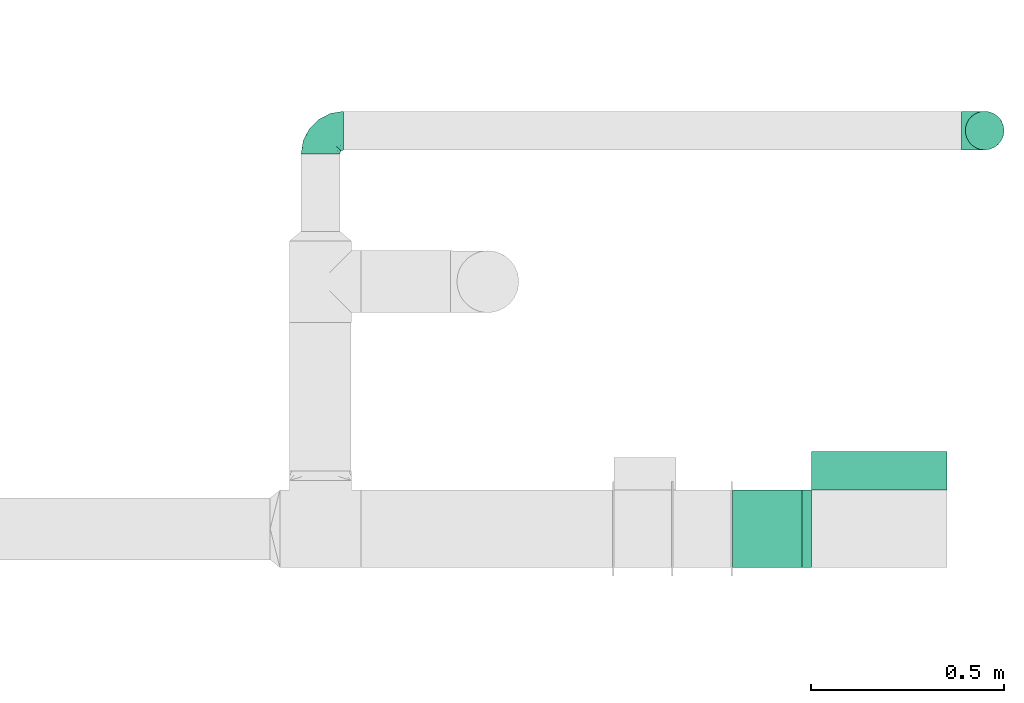
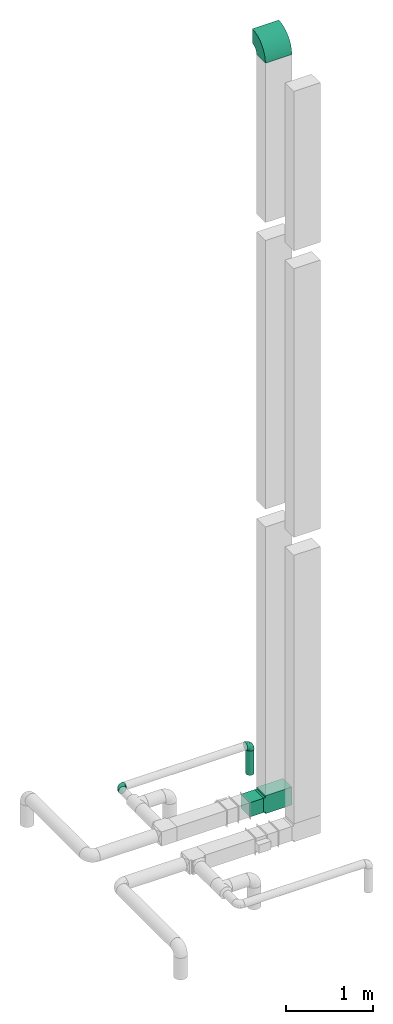
# One storey, part 11 of 12: 4 flow fittings, 2 flow segments.
"""IFC2X3 building model written with IfcOpenShell, lengths in millimetres."""

from ifc_helpers import new_model, entity, si_unit, converted_unit, derived_unit, direction, frame, frame_2d, origin, origin_2d_with_axis, place, context, subcontext, project, spatial, polyline, circle_curve, parameter, trimmed, segment, composite_curve, rectangle, circle, outline, extrude, faceted_brep, source, transform, mapped, type_object, type_shapes, element, save


model = new_model("IFC2X3")

# Units and contexts
model_context = context("Model", 3, precision=0.01, world=origin(), true_north=direction((6.12303176911189e-17, 1.0)))
body_context = subcontext(model_context, "Body", "Model", "MODEL_VIEW")
ifc_project = project(units=[si_unit("LENGTHUNIT", "METRE", prefix="MILLI"), si_unit("AREAUNIT", "SQUARE_METRE"), si_unit("VOLUMEUNIT", "CUBIC_METRE"), converted_unit("PLANEANGLEUNIT", "DEGREE", entity("IfcRatioMeasure", 0.0174532925199433), si_unit("PLANEANGLEUNIT", "RADIAN"), dimensions=[0, 0, 0, 0, 0, 0, 0]), si_unit("MASSUNIT", "GRAM", prefix="KILO"), derived_unit("MASSDENSITYUNIT", [(si_unit("MASSUNIT", "GRAM", prefix="KILO"), 1), (si_unit("LENGTHUNIT", "METRE"), -3)]), si_unit("TIMEUNIT", "SECOND"), si_unit("FREQUENCYUNIT", "HERTZ"), si_unit("THERMODYNAMICTEMPERATUREUNIT", "DEGREE_CELSIUS"), derived_unit("THERMALTRANSMITTANCEUNIT", [(si_unit("MASSUNIT", "GRAM", prefix="KILO"), 1), (si_unit("THERMODYNAMICTEMPERATUREUNIT", "KELVIN"), -1), (si_unit("TIMEUNIT", "SECOND"), -3)]), derived_unit("VOLUMETRICFLOWRATEUNIT", [(si_unit("LENGTHUNIT", "METRE"), 3), (si_unit("TIMEUNIT", "SECOND"), -1)]), si_unit("ELECTRICCURRENTUNIT", "AMPERE"), si_unit("ELECTRICVOLTAGEUNIT", "VOLT"), si_unit("POWERUNIT", "WATT"), si_unit("FORCEUNIT", "NEWTON", prefix="KILO"), si_unit("ILLUMINANCEUNIT", "LUX"), si_unit("LUMINOUSFLUXUNIT", "LUMEN"), si_unit("LUMINOUSINTENSITYUNIT", "CANDELA"), derived_unit("USERDEFINED", [(si_unit("MASSUNIT", "GRAM", prefix="KILO"), -1), (si_unit("LENGTHUNIT", "METRE"), -2), (si_unit("TIMEUNIT", "SECOND"), 3), (si_unit("LUMINOUSFLUXUNIT", "LUMEN"), 1)]), derived_unit("LINEARVELOCITYUNIT", [(si_unit("LENGTHUNIT", "METRE"), 1), (si_unit("TIMEUNIT", "SECOND"), -1)]), si_unit("PRESSUREUNIT", "PASCAL"), derived_unit("USERDEFINED", [(si_unit("LENGTHUNIT", "METRE"), -2), (si_unit("MASSUNIT", "GRAM", prefix="KILO"), 1), (si_unit("TIMEUNIT", "SECOND"), -2)])], contexts=[model_context])

# Site, building, storey
site_placement = place(None, origin())
site = spatial("IfcSite", under=ifc_project, at=site_placement, CompositionType="ELEMENT")
building_placement = place(site_placement, origin())
building = spatial("IfcBuilding", under=site, at=building_placement, CompositionType="ELEMENT")
storey_placement = place(building_placement, frame((0.0, 0.0, 4000.0)))
storey = spatial("IfcBuildingStorey", under=building, at=storey_placement, Name="01 Level", CompositionType="ELEMENT", Elevation=4000.0)

# Flow segments
duct_segment_type_1 = type_object("IfcDuctSegmentType", Name="Round Duct:Air", PredefinedType="NOTDEFINED")
flow_segment_1_placement = place(storey_placement, frame((24851.8947986159, -67528.1388300248, 2603.07847999992)))
element("IfcFlowSegment", 1, at=flow_segment_1_placement, inside=storey, type_object=duct_segment_type_1, Name="Round Duct:Air", ObjectType="Round Duct:Air", context=body_context, shape_type="SweptSolid", body=[
    extrude(circle(Radius=50.0, at=origin_2d_with_axis()), frame((51.5952722359175, 51.5952722359132, 0.0), z_axis=(0.0, 0.0, 1.0), x_axis=(0.0, 1.0, 0.0)), (0.0, 0.0, 1.0), 336.921519999948),
])
duct_segment_type_2 = type_object("IfcDuctSegmentType", Name="Rectangular Duct:Air", PredefinedType="NOTDEFINED")
flow_segment_2_placement = place(storey_placement, frame((24250.9900708518, -68606.4439409626, 2900.0)))
element("IfcFlowSegment", 2, at=flow_segment_2_placement, inside=storey, type_object=duct_segment_type_2, Name="Rectangular Duct:Air", ObjectType="Rectangular Duct:Air", context=body_context, shape_type="SweptSolid", body=[
    extrude(rectangle(XDim=179.671447124557, YDim=199.999999999998, at=frame_2d((0.0, -4.33431068813661e-12), x_axis=(1.0, 0.0))), frame((89.8357235622787, 100.0, 0.0)), (0.0, 0.0, 1.0), 200.0),
])

# Flow fittings
duct_fitting_type_1 = type_object("IfcDuctFittingType", Name="Air_Elbow short_Circ", PredefinedType="NOTDEFINED")
shared_shape_1 = source(origin(), body_context, "Body", "Brep", [
    faceted_brep([(-60.0, -12.9409522551261, -48.2962913144533), (-60.0, -25.0, -43.3012701892219), (-60.0, -35.3553390593274, -35.3553390593273), (-60.0, -43.3012701892219, -25.0), (-60.0, -48.2962913144534, -12.940952255126), (-60.0, -50.0, 0.0), (-60.0, -48.2962913144533, 12.9409522551263), (-60.0, -43.3012701892217, 25.0), (-60.0, -35.3553390593271, 35.3553390593275), (-60.0, -25.0, 43.301270189222), (-60.0, -18.9704761275628, 45.7987807518377), (-60.0, -12.9409522551258, 48.2962913144534), (-60.0, 0.0, 50.0), (-60.0, 12.9409522551262, 48.2962913144533), (-60.0, 25.0, 43.3012701892218), (-60.0, 35.3553390593275, 35.3553390593272), (-60.0, 43.301270189222, 25.0), (-60.0, 48.2962913144534, 12.9409522551259), (-60.0, 50.0, 0.0), (-60.0, 48.2962913144533, -12.9409522551262), (-60.0, 43.3012701892218, -25.0), (-60.0, 35.3553390593273, -35.3553390593274), (-60.0, 25.0, -43.3012701892219), (-60.0, 12.9409522551259, -48.2962913144534), (-60.0, 0.0, -50.0), (0.0, -60.0, -50.0), (12.9409522551268, -60.0, -48.2962913144534), (25.0, -60.0, -43.3012701892219), (35.3553390593281, -60.0, -35.3553390593274), (43.3012701892227, -60.0, -25.0), (48.2962913144542, -60.0, -12.9409522551262), (50.0, -60.0, 0.0), (48.2962913144543, -60.0, 12.9409522551259), (43.3012701892229, -60.0, 25.0), (35.3553390593284, -60.0, 35.3553390593272), (25.0, -60.0, 43.3012701892218), (12.9409522551271, -60.0, 48.2962913144533), (0.0, -60.0, 50.0), (-12.9409522551249, -60.0, 48.2962913144534), (-25.0, -60.0, 43.301270189222), (-35.3553390593263, -60.0, 35.3553390593275), (-43.3012701892209, -60.0, 25.0), (-48.2962913144524, -60.0, 12.9409522551263), (-50.0, -60.0, 0.0), (-48.2962913144525, -60.0, -12.940952255126), (-43.301270189221, -60.0, -25.0), (-35.3553390593265, -60.0, -35.3553390593273), (-25.0, -60.0, -43.3012701892219), (-18.9704761275622, -60.0, -45.7987807518376), (-12.9409522551252, -60.0, -48.2962913144533), (-34.4613055182162, 40.2781615499549, 24.6893391361235), (-41.7413930879589, 46.3367006663211, 14.3622192349088), (-49.0564079906538, 40.7801415025898, 28.076858272246), (-43.0040653093767, 47.3081083962334, 0.0), (-46.9531334224505, -28.9691372331723, 42.5007483631415), (-49.945230570524, -14.009456366224, 48.3010541644054), (46.3367008388525, -41.7413924405609, 14.3622183025403), (-28.9195822317624, 34.3595042325614, 30.8522337271345), (-16.4026032888538, 28.8335615486346, 31.3447155376829), (-20.8886043148544, 37.032907476011, 22.5646988156665), (8.51327307359233, -29.8490270681828, 47.7425705251578), (21.5851347328685, -39.3600400603544, 43.7780030266717), (18.1051423029501, -18.6630708487668, 41.1725129713058), (-3.94145017646366, -44.1513377558611, 49.9695692624666), (-16.993357552601, -43.112835299455, 48.0588376259554), (-29.8490305613342, 8.51327565171467, 47.7425702287428), (-18.6630773197735, 18.1051465687322, 41.1725124591201), (-39.360041631582, 21.585137213725, 43.7780019122438), (-41.9572959526986, 32.3456520264411, 36.575294220854), (-28.3738768436699, 26.9110252548877, 38.0083212356069), (-47.8035915916317, -49.3365848090307, 24.1167211667097), (-51.9080682539527, -51.9080682564403, 11.9284381035673), (-28.9388870718402, -47.4392187660381, 42.4028289139121), (-46.4119732313288, 8.97786791845547, 48.9268647037242), (15.3655862372502, 1.44443599762982, 33.3656926605527), (12.7026747916207, 16.0653579926251, 21.330563165355), (-0.0901680697707372, 16.249793899354, 33.6631038709893), (-26.0984306641832, -9.4519602521943, 49.9925353018775), (-43.5357165770215, -3.92607608695299, 49.9756911723036), (-40.3512409746586, -17.2001159603688, 48.3058104561749), (-51.5116032222349, -38.9116886125261, 33.3337470302399), (40.2781623134548, -34.4613024546835, 24.689336501659), (34.3595052098631, -28.9195768148052, 30.852230382061), (32.3456522233896, -41.9572963751397, 36.5752941161915), (-52.6192947824697, -44.3162483434043, 26.0687788699409), (8.97786691245749, -46.4119718726044, 48.9268648562795), (35.0507691245895, -17.8379542600364, 23.7817320689175), (-0.154113830211583, 27.0441585303382, 20.4371969134619), (0.164802122834046, 30.9507973718637, 9.70158150296541), (-10.9191638901366, 35.9593562872322, 14.7243484546897), (40.7801421145919, -49.0564069362065, 28.0768572079665), (42.5446020921407, -25.3772134428819, 13.1791087429088), (23.1044280783399, 10.2139010010231, 10.911201952746), (10.303795037543, 23.1674391280597, 10.425151792526), (47.3081083962343, -43.0040653093781, 0.0), (44.6162167924678, -26.008130618756, 0.0), (-32.7984308187714, -33.1644722725009, 45.0025999357929), (-41.6246972537655, -41.624696659769, 36.6481760707585), (-16.0198594588589, -0.790040969679908, 48.0702532559686), (-7.74597844975689, -15.8760781607658, 49.2907901610601), (-10.2505184648613, -32.0701285913551, 49.9130990257927), (-52.9289321881336, -52.9289321881345, 0.0), (-38.9116885130941, -51.5116028691678, 33.3337472807585), (27.3373523634918, -28.9262874076833, 37.8242669720924), (28.8335585354312, -16.4025932897411, 31.3447134244473), (-10.6758764332908, 36.8040430868554, 0.0), (-21.0820556464647, -25.013405385062, 49.4085637061446), (-25.3772163464242, 42.5446022063287, 13.179111746218), (-29.4708300504911, -18.1716321771538, 49.3204506255928), (-0.613576836584022, -32.0726800049485, 49.6825501479137), (-26.0081306187546, 44.6162167924668, 0.0), (-1.21981718883359, -1.21981162112378, 44.3295369128094), (7.809323786389, -12.5506490133832, 44.518448707346), (4.65637775217312, 28.991869381244, 0.0), (30.9271083665945, 0.192011278925337, 9.72551394481069), (25.4694098156993, 0.899564345657441, 21.9045256717261), (36.8040430868565, -10.6758764332921, 0.0), (8.17237141004653, -0.709602060124845, 39.7363553078916), (-1.20691178924098, 8.42774890414073, 39.8368437988478), (-11.8311378719951, 8.12805454147699, 44.1670059112514), (16.8241235667092, 16.8241235667079, 0.0), (35.9593546638031, -10.9191599029529, 14.7243472530362), (28.9918693812452, 4.65637775217184, 0.0), (-14.0094588862512, -49.9452236085703, -48.3010539035587), (-25.3772156484835, 42.5446019119684, -13.1791119497906), (-34.4613048910139, 40.2781614393135, -24.6893390523416), (-41.7413926252934, 46.3367005832334, -14.3622192468898), (-43.1128355702084, -16.9933564311214, -48.0588378972243), (-44.1513388294639, -3.94144876101963, -49.969569299814), (-51.5116035577561, -38.9116884747343, -33.3337470330805), (-41.62469790636, -41.6246960630329, -36.6481760341003), (-49.3365851024771, -47.8035917204495, -24.1167206397972), (16.0653446591387, 12.7026862735946, -21.330566780897), (10.2138986720569, 23.1044286164337, -10.9112068363266), (23.1674375203698, 10.3037953844737, -10.4251565011195), (27.0441512446144, -0.154114142874967, -20.4372107139949), (30.9507965291521, 0.164803474452689, -9.70158128624016), (35.9593546209329, -10.9191616413996, -14.7243499458666), (-28.9262923378956, 27.3373567288812, -37.8242648451571), (-16.4026019873643, 28.8335613017021, -31.344715100551), (-18.6630757642047, 18.1051470727615, -41.1725116507822), (-0.79004904716724, -16.0198534732482, -48.0702540902608), (-9.45196719952168, -26.0984311316614, -49.9925354060889), (-15.8760743141415, -7.74597807562093, -49.2907896898935), (-25.0134056140136, -21.0820528609103, -49.4085640038716), (-49.0564077792961, 40.7801415002595, -28.0768582420378), (-33.1644687800828, -32.7984277324913, -45.0026021871039), (-47.4392196421628, -28.9388866268174, -42.4028289664685), (-51.9080682748156, -51.9080682458111, -11.9284380741106), (-39.3600407942016, 21.5851376014369, -43.7780015915287), (-41.9572952892088, 32.3456521258773, -36.5752940113004), (-29.8490289400598, 8.5132766456386, -47.7425697425162), (-46.411972568153, 8.97786849540185, -48.9268645575236), (-17.8379596675892, 35.0507702162708, -23.7817342784206), (-28.9195813138317, 34.3595041939927, -30.8522334076151), (18.1051443153088, -18.6630730295509, -41.1725124486671), (26.9110256448416, -28.3738769796432, -38.0083209621406), (21.5851368100191, -39.3600388626355, -43.7780017534797), (-44.316248159738, -52.6192941440622, -26.0687795868405), (-38.911688364674, -51.5116023985273, -33.3337476311683), (-3.92607321834031, -43.5357049838062, -49.9756913600445), (-17.2001201011705, -40.3512365316697, -48.3058099460363), (8.97786798225732, -46.4119703958823, -48.9268645751331), (8.51327412363391, -29.8490256018375, -47.7425700423665), (40.7801413413476, -49.0564079294803, -28.0768584987253), (-28.969136268001, -46.9531365639949, -42.5007481599507), (1.44442453081588, 15.3655954628303, -33.3656927670723), (16.2497893015437, -0.0901603719773552, -33.6631026184802), (32.3456517066656, -41.9572939682546, -36.5752941586943), (46.3367004266908, -41.7413922128929, -14.3622195286513), (28.8335602968518, -16.402602640196, -31.3447165791004), (37.0329066484517, -20.888602858321, -22.564699256686), (34.3595039081184, -28.9195810717321, -30.8522336573022), (40.2781610753798, -34.461304879185, -24.6893396682814), (-32.0701289123428, -10.2505155181949, -49.9130991682027), (42.5446013435109, -25.3772148558883, -13.1791129929581), (-18.17163862849, -29.4708285244359, -49.3204499074468), (-32.0726819537407, -0.61357350659226, -49.6825499006192), (-1.21981337419447, -1.21981084831843, -44.3295352204376), (-12.5506417422758, 7.80933382246174, -44.5184423716321), (0.192009591001318, 30.9271092740971, -9.72551482732434), (0.899550937376629, 25.4694163362272, -21.9045307406697), (-0.709596078235449, 8.17237239935393, -39.7363517396473), (8.42775025848031, -1.2069144200305, -39.8368443201002), (8.12805004108825, -11.8311369938791, -44.1670075921659), (-10.9191629014402, 35.9593557213529, -14.724348628576)], [[[0, 1, 2, 3, 4, 5, 6, 7, 8, 9, 10, 11, 12, 13, 14, 15, 16, 17, 18, 19, 20, 21, 22, 23, 24]], [[25, 26, 27, 28, 29, 30, 31, 32, 33, 34, 35, 36, 37, 38, 39, 40, 41, 42, 43, 44, 45, 46, 47, 48, 49]], [[50, 51, 52]], [[18, 17, 53]], [[9, 54, 55]], [[32, 56, 33]], [[57, 58, 59]], [[60, 61, 62]], [[63, 64, 38]], [[65, 66, 67]], [[67, 68, 14]], [[68, 69, 57]], [[42, 70, 71]], [[52, 16, 15]], [[64, 72, 39]], [[73, 13, 12]], [[74, 75, 76]], [[55, 11, 10, 9]], [[77, 78, 79]], [[67, 14, 13]], [[17, 16, 51]], [[7, 80, 8]], [[81, 82, 83]], [[7, 84, 80]], [[8, 54, 9]], [[72, 40, 39]], [[5, 71, 6]], [[73, 65, 67]], [[85, 37, 36]], [[7, 6, 84]], [[85, 36, 61]], [[81, 86, 82]], [[87, 88, 89]], [[35, 61, 36]], [[33, 90, 34]], [[38, 37, 63]], [[91, 81, 56]], [[90, 33, 56]], [[35, 83, 61]], [[75, 92, 93]], [[94, 95, 56]], [[96, 97, 72]], [[98, 77, 99]], [[64, 63, 100]], [[71, 5, 101]], [[68, 15, 14]], [[43, 71, 101]], [[66, 69, 67]], [[70, 102, 97]], [[103, 104, 62]], [[40, 102, 41]], [[105, 89, 88]], [[70, 42, 41]], [[96, 72, 64]], [[77, 106, 99]], [[64, 39, 38]], [[78, 12, 11]], [[59, 89, 107]], [[35, 34, 83]], [[91, 86, 81]], [[51, 53, 17]], [[56, 32, 94]], [[12, 78, 73]], [[106, 77, 108]], [[96, 108, 79]], [[97, 54, 80]], [[40, 72, 102]], [[96, 54, 97]], [[106, 64, 100]], [[85, 109, 63]], [[61, 83, 103]], [[81, 83, 90]], [[15, 68, 52]], [[50, 68, 57]], [[77, 65, 78]], [[53, 51, 110]], [[94, 32, 31]], [[65, 77, 98]], [[111, 99, 112]], [[63, 109, 100]], [[107, 51, 50]], [[93, 113, 88]], [[114, 92, 115]], [[74, 62, 104]], [[115, 74, 104]], [[91, 95, 116]], [[112, 117, 111]], [[115, 75, 74]], [[117, 118, 111]], [[111, 118, 119]], [[58, 66, 76]], [[111, 119, 98]], [[87, 58, 76]], [[118, 117, 74]], [[54, 96, 79]], [[106, 96, 64]], [[120, 113, 93]], [[86, 121, 115]], [[122, 92, 114]], [[120, 92, 122]], [[115, 92, 75]], [[120, 93, 92]], [[87, 75, 93]], [[75, 87, 76]], [[58, 87, 59]], [[37, 85, 63]], [[60, 85, 61]], [[13, 73, 67]], [[65, 73, 78]], [[107, 110, 51]], [[121, 116, 114]], [[116, 121, 91]], [[91, 56, 95]], [[41, 102, 70]], [[97, 102, 72]], [[8, 80, 54]], [[70, 97, 84]], [[100, 99, 106]], [[60, 99, 109]], [[100, 109, 99]], [[60, 109, 85]], [[93, 88, 87]], [[89, 105, 107]], [[80, 84, 97]], [[71, 70, 84]], [[84, 6, 71]], [[42, 71, 43]], [[16, 52, 51]], [[50, 52, 68]], [[34, 90, 83]], [[81, 90, 56]], [[79, 78, 55]], [[11, 55, 78]], [[54, 79, 55]], [[61, 103, 62]], [[104, 103, 82]], [[83, 82, 103]], [[104, 82, 86]], [[104, 86, 115]], [[91, 121, 86]], [[50, 57, 59]], [[58, 57, 69]], [[58, 69, 66]], [[67, 69, 68]], [[50, 59, 107]], [[87, 89, 59]], [[106, 108, 96]], [[108, 77, 79]], [[66, 65, 119]], [[111, 98, 99]], [[98, 119, 65]], [[76, 66, 118]], [[119, 118, 66]], [[76, 118, 74]], [[117, 62, 74]], [[62, 117, 112]], [[112, 60, 62]], [[60, 112, 99]], [[110, 107, 105]], [[105, 88, 113]], [[122, 114, 116]], [[121, 114, 115]], [[49, 48, 47, 123]], [[124, 125, 126]], [[0, 127, 1]], [[128, 0, 24]], [[129, 130, 131]], [[132, 133, 134]], [[2, 129, 3]], [[135, 136, 137]], [[131, 4, 3]], [[138, 139, 140]], [[141, 142, 143]], [[143, 142, 144]], [[145, 20, 126]], [[146, 130, 147]], [[53, 110, 126]], [[4, 131, 148]], [[149, 22, 150]], [[151, 149, 140]], [[22, 149, 23]], [[146, 147, 127]], [[147, 2, 1]], [[21, 20, 145]], [[150, 22, 21]], [[149, 152, 23]], [[125, 153, 154]], [[125, 154, 150]], [[148, 101, 5]], [[124, 153, 125]], [[148, 44, 43]], [[155, 156, 157]], [[158, 159, 45]], [[157, 27, 26]], [[116, 137, 136]], [[45, 159, 46]], [[1, 127, 147]], [[142, 160, 161]], [[162, 163, 157]], [[164, 29, 28]], [[165, 47, 46]], [[166, 132, 167]], [[25, 162, 26]], [[27, 157, 168]], [[128, 127, 0]], [[30, 29, 169]], [[170, 171, 172]], [[155, 157, 163]], [[152, 24, 23]], [[169, 164, 173]], [[160, 25, 49]], [[30, 94, 31]], [[168, 28, 27]], [[127, 128, 174]], [[168, 156, 172]], [[47, 165, 123]], [[19, 126, 20]], [[169, 94, 30]], [[5, 4, 148]], [[171, 137, 175]], [[45, 44, 158]], [[126, 19, 53]], [[25, 160, 162]], [[144, 142, 176]], [[146, 176, 161]], [[130, 165, 159]], [[2, 147, 129]], [[146, 165, 130]], [[144, 127, 174]], [[152, 177, 128]], [[149, 150, 138]], [[125, 150, 145]], [[28, 168, 164]], [[173, 168, 172]], [[142, 163, 160]], [[94, 169, 95]], [[53, 19, 18]], [[163, 142, 141]], [[178, 143, 179]], [[128, 177, 174]], [[175, 169, 173]], [[134, 122, 136]], [[180, 133, 181]], [[166, 140, 139]], [[181, 166, 139]], [[124, 110, 105]], [[179, 182, 178]], [[181, 132, 166]], [[182, 183, 178]], [[178, 183, 184]], [[170, 155, 167]], [[178, 184, 141]], [[135, 170, 167]], [[183, 182, 166]], [[165, 146, 161]], [[144, 146, 127]], [[120, 122, 134]], [[153, 185, 181]], [[113, 133, 180]], [[120, 133, 113]], [[181, 133, 132]], [[120, 134, 133]], [[135, 132, 134]], [[132, 135, 167]], [[170, 135, 171]], [[24, 152, 128]], [[151, 152, 149]], [[26, 162, 157]], [[163, 162, 160]], [[175, 95, 169]], [[185, 105, 180]], [[105, 185, 124]], [[124, 126, 110]], [[3, 129, 131]], [[130, 129, 147]], [[46, 159, 165]], [[131, 130, 158]], [[174, 143, 144]], [[151, 143, 177]], [[174, 177, 143]], [[151, 177, 152]], [[134, 136, 135]], [[137, 116, 175]], [[159, 158, 130]], [[148, 131, 158]], [[101, 148, 43]], [[158, 44, 148]], [[29, 164, 169]], [[173, 164, 168]], [[21, 145, 150]], [[125, 145, 126]], [[161, 160, 123]], [[49, 123, 160]], [[165, 161, 123]], [[149, 138, 140]], [[139, 138, 154]], [[150, 154, 138]], [[139, 154, 153]], [[139, 153, 181]], [[124, 185, 153]], [[173, 172, 171]], [[170, 172, 156]], [[170, 156, 155]], [[157, 156, 168]], [[173, 171, 175]], [[135, 137, 171]], [[144, 176, 146]], [[176, 142, 161]], [[155, 163, 184]], [[178, 141, 143]], [[141, 184, 163]], [[167, 155, 183]], [[184, 183, 155]], [[167, 183, 166]], [[182, 140, 166]], [[140, 182, 179]], [[179, 151, 140]], [[151, 179, 143]], [[95, 175, 116]], [[116, 136, 122]], [[113, 180, 105]], [[185, 180, 181]]]),
])
type_shapes(duct_fitting_type_1, [shared_shape_1])
for number, where, z_axis, x_axis, name in (
    (3, (24903.4900708518, -67476.5435577884, 3000.0), (0.0, 1.0, 0.0), (0.0, 0.0, 1.0), "elbow_short_001:Air_Elbow short_Circ"),
    (4, (23185.9900708518, -67476.5435577883, 3000.0), (0.0, 0.0, 1.0), (0.0, 1.0, 0.0), "elbow_short_001:Air_Elbow short_Circ"),
):
    element("IfcFlowFitting", number, at=place(storey_placement, frame(where, z_axis=z_axis, x_axis=x_axis)), inside=storey, type_object=duct_fitting_type_1, Name=name, ObjectType="elbow_short_001:Air_Elbow short_Circ", context=body_context, shape_type="MappedRepresentation", body=[
        mapped(shared_shape_1, transform((0.0, 0.0, 0.0), scale=1.0)),
    ])
duct_fitting_type_2 = type_object("IfcDuctFittingType", Name="Air_Rect", PredefinedType="NOTDEFINED")
shared_shape_2 = source(origin(), body_context, "Body", "SweptSolid", [
    extrude(outline(polyline([(-81.2499999999996, -125.0), (268.75, -125.0), (268.75, 125.0), (-81.2500000000004, 125.0), (-81.2500000000003, 100.0), (-106.25, 100.0), (-106.25, -100.0), (-81.2499999999997, -100.0), (-81.2499999999996, -125.0)])), frame((0.0, 93.75, -100.0), z_axis=(0.0, 0.0, 1.0), x_axis=(0.0, -1.0, 0.0)), (0.0, 0.0, 1.0), 200.0),
])
type_shapes(duct_fitting_type_2, [shared_shape_2])
flow_fitting_1_placement = place(storey_placement, frame((24630.6615179764, -68506.4439409627, 3000.0), z_axis=(0.0, 1.0, 0.0), x_axis=(0.0, 0.0, -1.0)))
element("IfcFlowFitting", 5, at=flow_fitting_1_placement, inside=storey, type_object=duct_fitting_type_2, Name="1_001:Air_Rect", ObjectType="1_001:Air_Rect", context=body_context, shape_type="MappedRepresentation", body=[
    mapped(shared_shape_2, transform((0.0, 0.0, 0.0), scale=1.0)),
])
duct_fitting_type_3 = type_object("IfcDuctFittingType", Name="Air_Elbow_Rect", PredefinedType="NOTDEFINED")
shared_shape_3 = source(origin(), body_context, "Body", "SweptSolid", [
    extrude(outline(composite_curve([segment(polyline([(-200.0, -100.0), (0.0, -100.0)]), True, "CONTINUOUS"), segment(trimmed(circle_curve(frame_2d((100.0, -100.0), x_axis=(0.0, 1.0)), 100.0), [parameter(0.0)], [parameter(90.0000000000001)], True, "PARAMETER"), False, "CONTINUOUS"), segment(polyline([(100.0, 0.0), (100.0, 200.0)]), True, "CONTINUOUS"), segment(trimmed(circle_curve(frame_2d((100.0, -100.0), x_axis=(0.0, 1.0)), 300.0), [parameter(0.0)], [parameter(90.0000000000001)], True, "PARAMETER"), True, "CONTINUOUS")], self_intersect=False)), frame((-100.0, 100.0, -175.0), z_axis=(0.0, 0.0, 1.0), x_axis=(-1.0, 0.0, 0.0)), (0.0, 0.0, 1.0), 350.0),
])
type_shapes(duct_fitting_type_3, [shared_shape_3])
flow_fitting_2_placement = place(storey_placement, frame((24630.6615179764, -68506.4439409627, 13550.0), z_axis=(-1.0, 0.0, 0.0), x_axis=(0.0, 0.0, 1.0)))
element("IfcFlowFitting", 6, at=flow_fitting_2_placement, inside=storey, type_object=duct_fitting_type_3, Name="elbow1_001:Air_Elbow_Rect", ObjectType="elbow1_001:Air_Elbow_Rect", context=body_context, shape_type="MappedRepresentation", body=[
    mapped(shared_shape_3, transform((0.0, 0.0, 0.0), scale=1.0)),
])

save(model, "model.ifc")
